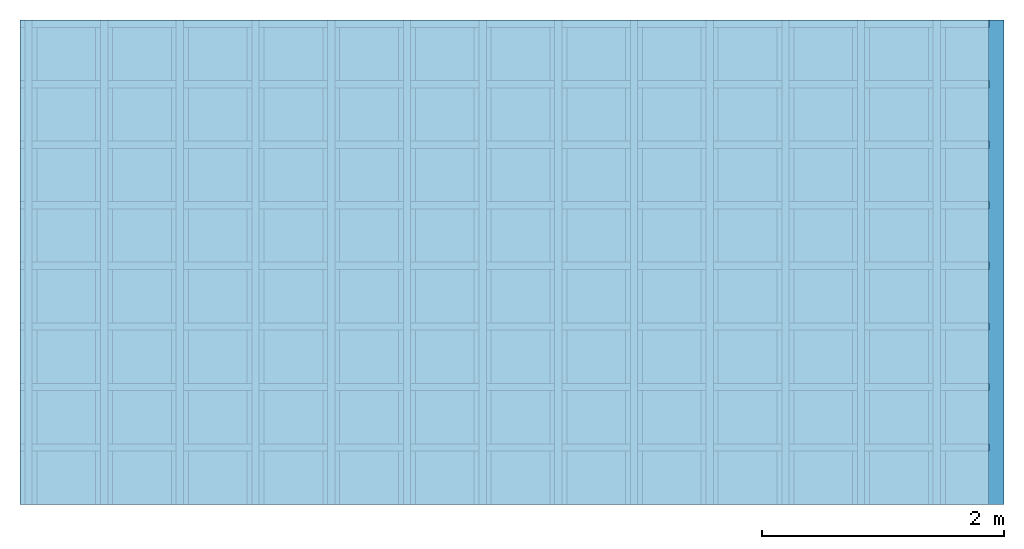
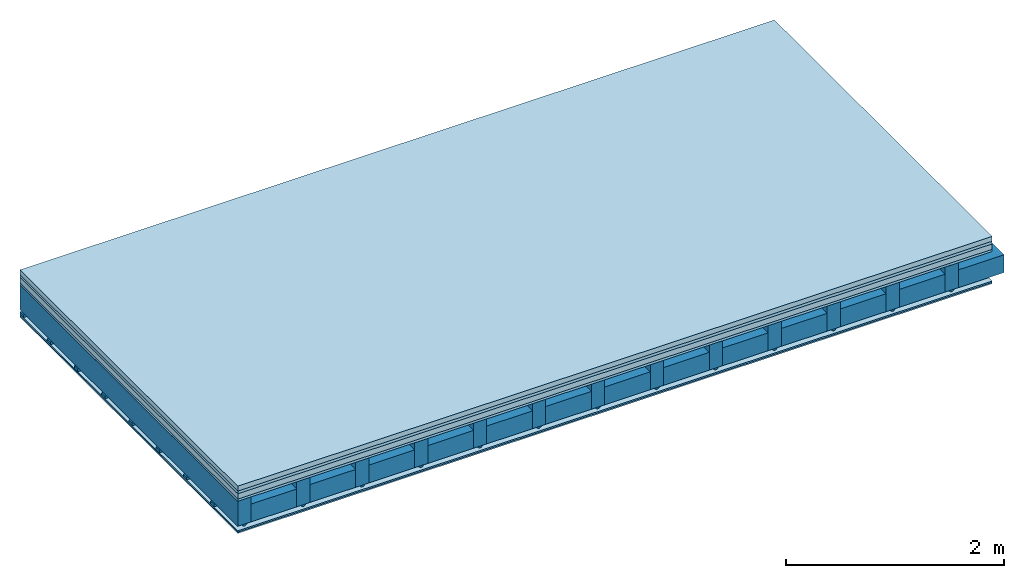
# One storey: 6 plates, 4 members, 1 element without a shape of its own.
"""IFC4 building model written with IfcOpenShell, lengths in metres."""

from ifc_helpers import new_model, si_unit, derived_unit, direction, frame, frame_2d, origin, origin_with_axes, place, context, project, spatial, polyline, rectangle, outline, extrude, material, layer, layer_set, type_object, element, aggregate, save


model = new_model("IFC4")

# Units and contexts
plan_context = context("Plan", 3, precision=1e-05, world=origin(), true_north=direction((0.0, 1.0)))
model_context = context("Model", 3, precision=1e-05, world=origin(), true_north=direction((0.0, 1.0)))
ifc_project = project(units=[si_unit("LENGTHUNIT", "METRE"), derived_unit("SOUNDPRESSUREUNIT", [(si_unit("PRESSUREUNIT", "PASCAL", prefix="MICRO"), 0)]), si_unit("ENERGYUNIT", "JOULE", prefix="MEGA"), si_unit("MASSUNIT", "GRAM", prefix="KILO"), derived_unit("THERMALTRANSMITTANCEUNIT", [(si_unit("POWERUNIT", "WATT"), 1), (si_unit("AREAUNIT", "SQUARE_METRE"), -1), (si_unit("THERMODYNAMICTEMPERATUREUNIT", "KELVIN"), -1)]), derived_unit("AREADENSITYUNIT", [(si_unit("MASSUNIT", "GRAM", prefix="KILO"), 1), (si_unit("AREAUNIT", "SQUARE_METRE"), -1)]), derived_unit("USERDEFINED", [(si_unit("ENERGYUNIT", "JOULE", prefix="MEGA"), 1), (si_unit("AREAUNIT", "SQUARE_METRE"), -1)])], contexts=[plan_context, model_context])

# Site, building, storey
site = spatial("IfcSite", under=ifc_project)
building_placement = place(None, origin())
building = spatial("IfcBuilding", under=site, at=building_placement)
storey_placement = place(building_placement, origin())
storey = spatial("IfcBuildingStorey", under=building, at=storey_placement)

# Slab, members, plates
ifc_material_1 = material(Category="04.005")
ifc_layer_1 = layer(ifc_material_1, 0.055, Name="On-material")
ifc_material_2 = material()
ifc_layer_2 = layer(ifc_material_2, 0.03, Name="Impact sound insulation")
ifc_material_3 = material(Name="Cement panels, glued on sub-floor", Category="02.007")
ifc_layer_3 = layer(ifc_material_3, 0.06, Name="on Supporting structure")
ifc_material_4 = material(Category="07.001")
ifc_layer_4 = layer(ifc_material_4, 0.025, Name="Sub-floor")
ifc_material_5 = material(Name="of the art")
ifc_layer_5 = layer(ifc_material_5, 0.0, Name="Bond")
ifc_layer_6 = layer(None, 0.28, Name="Supporting structure")
ifc_material_6 = material(Name="no composite action")
ifc_layer_7 = layer(ifc_material_6, 0.0, Name="Bond")
ifc_layer_8 = layer(None, 0.02, Name="Coupling")
ifc_layer_9 = layer(None, 0.03, Name="Battens / profiles")
ifc_material_7 = material(Name="Plasterboard type A", Category="03.008")
ifc_layer_10 = layer(ifc_material_7, 0.015, Name="Ceiling covering 1st layer")
ifc_layer_11 = layer(ifc_material_7, 0.015, Name="Ceiling covering layer 2")
ifc_material_8 = material(Name="joints", Category="04.017")
ifc_layer_12 = layer(ifc_material_8, 0.0, Name="Surface / treatment")
ifc_layer_set = layer_set([ifc_layer_1, ifc_layer_2, ifc_layer_3, ifc_layer_4, ifc_layer_5, ifc_layer_6, ifc_layer_7, ifc_layer_8, ifc_layer_9, ifc_layer_10, ifc_layer_11, ifc_layer_12])
slab_type = type_object("IfcSlabType", Name="A0252", PredefinedType="NOTDEFINED", material=ifc_layer_set)
slab_placement = place(None, frame((0.0, 0.0, 0.0), z_axis=(0.0, 0.0, -1.0), x_axis=(1.0, 0.0, 0.0)))
slab = element("IfcSlab", 1, at=slab_placement, inside=storey, type_object=slab_type, material=ifc_layer_set, Name="Slab #1")
ifc_material_9 = material()
member_1_placement = place(slab_placement, origin())
member_1 = element("IfcMember", 2, at=member_1_placement, material=ifc_material_9, Name="Supporting structure", context=plan_context, shape_type="SweptSolid", body=[
    extrude(rectangle(XDim=0.14, YDim=0.28, at=frame_2d((0.07, 0.14), x_axis=(1.0, 0.0))), frame((0.0, 4.0, 0.17), z_axis=(0.0, -1.0, 0.0), x_axis=(1.0, 0.0, 0.0)), (0.0, 0.0, 1.0), 4.0),
    extrude(rectangle(XDim=0.14, YDim=0.28, at=frame_2d((0.07, 0.14), x_axis=(1.0, 0.0))), frame((0.625, 4.0, 0.17), z_axis=(0.0, -1.0, 0.0), x_axis=(1.0, 0.0, 0.0)), (0.0, 0.0, 1.0), 4.0),
    extrude(rectangle(XDim=0.14, YDim=0.28, at=frame_2d((0.07, 0.14), x_axis=(1.0, 0.0))), frame((1.25, 4.0, 0.17), z_axis=(0.0, -1.0, 0.0), x_axis=(1.0, 0.0, 0.0)), (0.0, 0.0, 1.0), 4.0),
    extrude(rectangle(XDim=0.14, YDim=0.28, at=frame_2d((0.07, 0.14), x_axis=(1.0, 0.0))), frame((1.875, 4.0, 0.17), z_axis=(0.0, -1.0, 0.0), x_axis=(1.0, 0.0, 0.0)), (0.0, 0.0, 1.0), 4.0),
    extrude(rectangle(XDim=0.14, YDim=0.28, at=frame_2d((0.07, 0.14), x_axis=(1.0, 0.0))), frame((2.5, 4.0, 0.17), z_axis=(0.0, -1.0, 0.0), x_axis=(1.0, 0.0, 0.0)), (0.0, 0.0, 1.0), 4.0),
    extrude(rectangle(XDim=0.14, YDim=0.28, at=frame_2d((0.07, 0.14), x_axis=(1.0, 0.0))), frame((3.125, 4.0, 0.17), z_axis=(0.0, -1.0, 0.0), x_axis=(1.0, 0.0, 0.0)), (0.0, 0.0, 1.0), 4.0),
    extrude(rectangle(XDim=0.14, YDim=0.28, at=frame_2d((0.07, 0.14), x_axis=(1.0, 0.0))), frame((3.75, 4.0, 0.17), z_axis=(0.0, -1.0, 0.0), x_axis=(1.0, 0.0, 0.0)), (0.0, 0.0, 1.0), 4.0),
    extrude(rectangle(XDim=0.14, YDim=0.28, at=frame_2d((0.07, 0.14), x_axis=(1.0, 0.0))), frame((4.375, 4.0, 0.17), z_axis=(0.0, -1.0, 0.0), x_axis=(1.0, 0.0, 0.0)), (0.0, 0.0, 1.0), 4.0),
    extrude(rectangle(XDim=0.14, YDim=0.28, at=frame_2d((0.07, 0.14), x_axis=(1.0, 0.0))), frame((5.0, 4.0, 0.17), z_axis=(0.0, -1.0, 0.0), x_axis=(1.0, 0.0, 0.0)), (0.0, 0.0, 1.0), 4.0),
    extrude(rectangle(XDim=0.14, YDim=0.28, at=frame_2d((0.07, 0.14), x_axis=(1.0, 0.0))), frame((5.625, 4.0, 0.17), z_axis=(0.0, -1.0, 0.0), x_axis=(1.0, 0.0, 0.0)), (0.0, 0.0, 1.0), 4.0),
    extrude(rectangle(XDim=0.14, YDim=0.28, at=frame_2d((0.07, 0.14), x_axis=(1.0, 0.0))), frame((6.25, 4.0, 0.17), z_axis=(0.0, -1.0, 0.0), x_axis=(1.0, 0.0, 0.0)), (0.0, 0.0, 1.0), 4.0),
    extrude(rectangle(XDim=0.14, YDim=0.28, at=frame_2d((0.07, 0.14), x_axis=(1.0, 0.0))), frame((6.875, 4.0, 0.17), z_axis=(0.0, -1.0, 0.0), x_axis=(1.0, 0.0, 0.0)), (0.0, 0.0, 1.0), 4.0),
    extrude(rectangle(XDim=0.14, YDim=0.28, at=frame_2d((0.07, 0.14), x_axis=(1.0, 0.0))), frame((7.5, 4.0, 0.17), z_axis=(0.0, -1.0, 0.0), x_axis=(1.0, 0.0, 0.0)), (0.0, 0.0, 1.0), 4.0),
])
ifc_material_10 = material()
member_2_placement = place(slab_placement, origin())
member_2 = element("IfcMember", 3, at=member_2_placement, material=ifc_material_10, Name="Cavity", context=plan_context, shape_type="SweptSolid", body=[
    extrude(rectangle(XDim=0.485, YDim=0.2, at=frame_2d((0.2425, 0.1), x_axis=(1.0, 0.0))), frame((0.14, 4.0, 0.25), z_axis=(0.0, -1.0, 0.0), x_axis=(1.0, 0.0, 0.0)), (0.0, 0.0, 1.0), 4.0),
    extrude(rectangle(XDim=0.485, YDim=0.2, at=frame_2d((0.2425, 0.1), x_axis=(1.0, 0.0))), frame((0.765, 4.0, 0.25), z_axis=(0.0, -1.0, 0.0), x_axis=(1.0, 0.0, 0.0)), (0.0, 0.0, 1.0), 4.0),
    extrude(rectangle(XDim=0.485, YDim=0.2, at=frame_2d((0.2425, 0.1), x_axis=(1.0, 0.0))), frame((1.39, 4.0, 0.25), z_axis=(0.0, -1.0, 0.0), x_axis=(1.0, 0.0, 0.0)), (0.0, 0.0, 1.0), 4.0),
    extrude(rectangle(XDim=0.485, YDim=0.2, at=frame_2d((0.2425, 0.1), x_axis=(1.0, 0.0))), frame((2.015, 4.0, 0.25), z_axis=(0.0, -1.0, 0.0), x_axis=(1.0, 0.0, 0.0)), (0.0, 0.0, 1.0), 4.0),
    extrude(rectangle(XDim=0.485, YDim=0.2, at=frame_2d((0.2425, 0.1), x_axis=(1.0, 0.0))), frame((2.64, 4.0, 0.25), z_axis=(0.0, -1.0, 0.0), x_axis=(1.0, 0.0, 0.0)), (0.0, 0.0, 1.0), 4.0),
    extrude(rectangle(XDim=0.485, YDim=0.2, at=frame_2d((0.2425, 0.1), x_axis=(1.0, 0.0))), frame((3.265, 4.0, 0.25), z_axis=(0.0, -1.0, 0.0), x_axis=(1.0, 0.0, 0.0)), (0.0, 0.0, 1.0), 4.0),
    extrude(rectangle(XDim=0.485, YDim=0.2, at=frame_2d((0.2425, 0.1), x_axis=(1.0, 0.0))), frame((3.89, 4.0, 0.25), z_axis=(0.0, -1.0, 0.0), x_axis=(1.0, 0.0, 0.0)), (0.0, 0.0, 1.0), 4.0),
    extrude(rectangle(XDim=0.485, YDim=0.2, at=frame_2d((0.2425, 0.1), x_axis=(1.0, 0.0))), frame((4.515, 4.0, 0.25), z_axis=(0.0, -1.0, 0.0), x_axis=(1.0, 0.0, 0.0)), (0.0, 0.0, 1.0), 4.0),
    extrude(rectangle(XDim=0.485, YDim=0.2, at=frame_2d((0.2425, 0.1), x_axis=(1.0, 0.0))), frame((5.14, 4.0, 0.25), z_axis=(0.0, -1.0, 0.0), x_axis=(1.0, 0.0, 0.0)), (0.0, 0.0, 1.0), 4.0),
    extrude(rectangle(XDim=0.485, YDim=0.2, at=frame_2d((0.2425, 0.1), x_axis=(1.0, 0.0))), frame((5.765, 4.0, 0.25), z_axis=(0.0, -1.0, 0.0), x_axis=(1.0, 0.0, 0.0)), (0.0, 0.0, 1.0), 4.0),
    extrude(rectangle(XDim=0.485, YDim=0.2, at=frame_2d((0.2425, 0.1), x_axis=(1.0, 0.0))), frame((6.39, 4.0, 0.25), z_axis=(0.0, -1.0, 0.0), x_axis=(1.0, 0.0, 0.0)), (0.0, 0.0, 1.0), 4.0),
    extrude(rectangle(XDim=0.485, YDim=0.2, at=frame_2d((0.2425, 0.1), x_axis=(1.0, 0.0))), frame((7.015, 4.0, 0.25), z_axis=(0.0, -1.0, 0.0), x_axis=(1.0, 0.0, 0.0)), (0.0, 0.0, 1.0), 4.0),
    extrude(rectangle(XDim=0.485, YDim=0.2, at=frame_2d((0.2425, 0.1), x_axis=(1.0, 0.0))), frame((7.64, 4.0, 0.25), z_axis=(0.0, -1.0, 0.0), x_axis=(1.0, 0.0, 0.0)), (0.0, 0.0, 1.0), 4.0),
])
ifc_material_11 = material()
member_3_placement = place(slab_placement, origin())
member_3 = element("IfcMember", 4, at=member_3_placement, material=ifc_material_11, Name="Coupling", context=plan_context, shape_type="SweptSolid", body=[
    extrude(outline(polyline([(0.0, 0.0), (0.06, 0.0), (0.04, 0.02), (0.02, 0.02), (0.0, 0.0)])), frame((0.04, 4.0, 0.45), z_axis=(0.0, -1.0, 0.0), x_axis=(1.0, 0.0, 0.0)), (0.0, 0.0, 1.0), 4.0),
    extrude(outline(polyline([(0.0, 0.0), (0.06, 0.0), (0.04, 0.02), (0.02, 0.02), (0.0, 0.0)])), frame((0.665, 4.0, 0.45), z_axis=(0.0, -1.0, 0.0), x_axis=(1.0, 0.0, 0.0)), (0.0, 0.0, 1.0), 4.0),
    extrude(outline(polyline([(0.0, 0.0), (0.06, 0.0), (0.04, 0.02), (0.02, 0.02), (0.0, 0.0)])), frame((1.29, 4.0, 0.45), z_axis=(0.0, -1.0, 0.0), x_axis=(1.0, 0.0, 0.0)), (0.0, 0.0, 1.0), 4.0),
    extrude(outline(polyline([(0.0, 0.0), (0.06, 0.0), (0.04, 0.02), (0.02, 0.02), (0.0, 0.0)])), frame((1.915, 4.0, 0.45), z_axis=(0.0, -1.0, 0.0), x_axis=(1.0, 0.0, 0.0)), (0.0, 0.0, 1.0), 4.0),
    extrude(outline(polyline([(0.0, 0.0), (0.06, 0.0), (0.04, 0.02), (0.02, 0.02), (0.0, 0.0)])), frame((2.54, 4.0, 0.45), z_axis=(0.0, -1.0, 0.0), x_axis=(1.0, 0.0, 0.0)), (0.0, 0.0, 1.0), 4.0),
    extrude(outline(polyline([(0.0, 0.0), (0.06, 0.0), (0.04, 0.02), (0.02, 0.02), (0.0, 0.0)])), frame((3.165, 4.0, 0.45), z_axis=(0.0, -1.0, 0.0), x_axis=(1.0, 0.0, 0.0)), (0.0, 0.0, 1.0), 4.0),
    extrude(outline(polyline([(0.0, 0.0), (0.06, 0.0), (0.04, 0.02), (0.02, 0.02), (0.0, 0.0)])), frame((3.79, 4.0, 0.45), z_axis=(0.0, -1.0, 0.0), x_axis=(1.0, 0.0, 0.0)), (0.0, 0.0, 1.0), 4.0),
    extrude(outline(polyline([(0.0, 0.0), (0.06, 0.0), (0.04, 0.02), (0.02, 0.02), (0.0, 0.0)])), frame((4.415, 4.0, 0.45), z_axis=(0.0, -1.0, 0.0), x_axis=(1.0, 0.0, 0.0)), (0.0, 0.0, 1.0), 4.0),
    extrude(outline(polyline([(0.0, 0.0), (0.06, 0.0), (0.04, 0.02), (0.02, 0.02), (0.0, 0.0)])), frame((5.04, 4.0, 0.45), z_axis=(0.0, -1.0, 0.0), x_axis=(1.0, 0.0, 0.0)), (0.0, 0.0, 1.0), 4.0),
    extrude(outline(polyline([(0.0, 0.0), (0.06, 0.0), (0.04, 0.02), (0.02, 0.02), (0.0, 0.0)])), frame((5.665, 4.0, 0.45), z_axis=(0.0, -1.0, 0.0), x_axis=(1.0, 0.0, 0.0)), (0.0, 0.0, 1.0), 4.0),
    extrude(outline(polyline([(0.0, 0.0), (0.06, 0.0), (0.04, 0.02), (0.02, 0.02), (0.0, 0.0)])), frame((6.29, 4.0, 0.45), z_axis=(0.0, -1.0, 0.0), x_axis=(1.0, 0.0, 0.0)), (0.0, 0.0, 1.0), 4.0),
    extrude(outline(polyline([(0.0, 0.0), (0.06, 0.0), (0.04, 0.02), (0.02, 0.02), (0.0, 0.0)])), frame((6.915, 4.0, 0.45), z_axis=(0.0, -1.0, 0.0), x_axis=(1.0, 0.0, 0.0)), (0.0, 0.0, 1.0), 4.0),
    extrude(outline(polyline([(0.0, 0.0), (0.06, 0.0), (0.04, 0.02), (0.02, 0.02), (0.0, 0.0)])), frame((7.54, 4.0, 0.45), z_axis=(0.0, -1.0, 0.0), x_axis=(1.0, 0.0, 0.0)), (0.0, 0.0, 1.0), 4.0),
])
ifc_material_12 = material()
member_4_placement = place(slab_placement, origin())
member_4 = element("IfcMember", 5, at=member_4_placement, material=ifc_material_12, Name="Battens / profiles", context=plan_context, shape_type="SweptSolid", body=[
    extrude(rectangle(XDim=0.06, YDim=0.03, at=frame_2d((0.03, 0.015), x_axis=(1.0, 0.0))), frame((0.0, 0.0, 0.47), z_axis=(1.0, 0.0, 0.0), x_axis=(0.0, 1.0, 0.0)), (0.0, 0.0, 1.0), 8.0),
    extrude(rectangle(XDim=0.06, YDim=0.03, at=frame_2d((0.03, 0.015), x_axis=(1.0, 0.0))), frame((0.0, 0.5, 0.47), z_axis=(1.0, 0.0, 0.0), x_axis=(0.0, 1.0, 0.0)), (0.0, 0.0, 1.0), 8.0),
    extrude(rectangle(XDim=0.06, YDim=0.03, at=frame_2d((0.03, 0.015), x_axis=(1.0, 0.0))), frame((0.0, 1.0, 0.47), z_axis=(1.0, 0.0, 0.0), x_axis=(0.0, 1.0, 0.0)), (0.0, 0.0, 1.0), 8.0),
    extrude(rectangle(XDim=0.06, YDim=0.03, at=frame_2d((0.03, 0.015), x_axis=(1.0, 0.0))), frame((0.0, 1.5, 0.47), z_axis=(1.0, 0.0, 0.0), x_axis=(0.0, 1.0, 0.0)), (0.0, 0.0, 1.0), 8.0),
    extrude(rectangle(XDim=0.06, YDim=0.03, at=frame_2d((0.03, 0.015), x_axis=(1.0, 0.0))), frame((0.0, 2.0, 0.47), z_axis=(1.0, 0.0, 0.0), x_axis=(0.0, 1.0, 0.0)), (0.0, 0.0, 1.0), 8.0),
    extrude(rectangle(XDim=0.06, YDim=0.03, at=frame_2d((0.03, 0.015), x_axis=(1.0, 0.0))), frame((0.0, 2.5, 0.47), z_axis=(1.0, 0.0, 0.0), x_axis=(0.0, 1.0, 0.0)), (0.0, 0.0, 1.0), 8.0),
    extrude(rectangle(XDim=0.06, YDim=0.03, at=frame_2d((0.03, 0.015), x_axis=(1.0, 0.0))), frame((0.0, 3.0, 0.47), z_axis=(1.0, 0.0, 0.0), x_axis=(0.0, 1.0, 0.0)), (0.0, 0.0, 1.0), 8.0),
    extrude(rectangle(XDim=0.06, YDim=0.03, at=frame_2d((0.03, 0.015), x_axis=(1.0, 0.0))), frame((0.0, 3.5, 0.47), z_axis=(1.0, 0.0, 0.0), x_axis=(0.0, 1.0, 0.0)), (0.0, 0.0, 1.0), 8.0),
])
plate_1_placement = place(slab_placement, origin())
plate_1 = element("IfcPlate", 6, at=plate_1_placement, material=ifc_material_1, Name="On-material", context=plan_context, shape_type="SweptSolid", body=[
    extrude(rectangle(XDim=8.0, YDim=4.0, at=frame_2d((4.0, 2.0), x_axis=(1.0, 0.0))), origin_with_axes(), (0.0, 0.0, 1.0), 0.055),
])
plate_2_placement = place(slab_placement, origin())
plate_2 = element("IfcPlate", 7, at=plate_2_placement, material=ifc_material_2, Name="Impact sound insulation", context=plan_context, shape_type="SweptSolid", body=[
    extrude(rectangle(XDim=8.0, YDim=4.0, at=frame_2d((4.0, 2.0), x_axis=(1.0, 0.0))), frame((0.0, 0.0, 0.055), z_axis=(0.0, 0.0, 1.0), x_axis=(1.0, 0.0, 0.0)), (0.0, 0.0, 1.0), 0.03),
])
plate_3_placement = place(slab_placement, origin())
plate_3 = element("IfcPlate", 8, at=plate_3_placement, material=ifc_material_3, Name="on Supporting structure", context=plan_context, shape_type="SweptSolid", body=[
    extrude(rectangle(XDim=8.0, YDim=4.0, at=frame_2d((4.0, 2.0), x_axis=(1.0, 0.0))), frame((0.0, 0.0, 0.085), z_axis=(0.0, 0.0, 1.0), x_axis=(1.0, 0.0, 0.0)), (0.0, 0.0, 1.0), 0.06),
])
plate_4_placement = place(slab_placement, origin())
plate_4 = element("IfcPlate", 9, at=plate_4_placement, material=ifc_material_4, Name="Sub-floor", context=plan_context, shape_type="SweptSolid", body=[
    extrude(rectangle(XDim=8.0, YDim=4.0, at=frame_2d((4.0, 2.0), x_axis=(1.0, 0.0))), frame((0.0, 0.0, 0.145), z_axis=(0.0, 0.0, 1.0), x_axis=(1.0, 0.0, 0.0)), (0.0, 0.0, 1.0), 0.025),
])
plate_5_placement = place(slab_placement, origin())
plate_5 = element("IfcPlate", 10, at=plate_5_placement, material=ifc_material_7, Name="Ceiling covering 1st layer", context=plan_context, shape_type="SweptSolid", body=[
    extrude(rectangle(XDim=8.0, YDim=4.0, at=frame_2d((4.0, 2.0), x_axis=(1.0, 0.0))), frame((0.0, 0.0, 0.5), z_axis=(0.0, 0.0, 1.0), x_axis=(1.0, 0.0, 0.0)), (0.0, 0.0, 1.0), 0.015),
])
plate_6_placement = place(slab_placement, origin())
plate_6 = element("IfcPlate", 11, at=plate_6_placement, material=ifc_material_7, Name="Ceiling covering layer 2", context=plan_context, shape_type="SweptSolid", body=[
    extrude(rectangle(XDim=8.0, YDim=4.0, at=frame_2d((4.0, 2.0), x_axis=(1.0, 0.0))), frame((0.0, 0.0, 0.515), z_axis=(0.0, 0.0, 1.0), x_axis=(1.0, 0.0, 0.0)), (0.0, 0.0, 1.0), 0.015),
])
aggregate(slab, [plate_1, plate_2, plate_3, plate_4, member_1, member_2, member_3, member_4, plate_5, plate_6])

save(model, "model.ifc")
